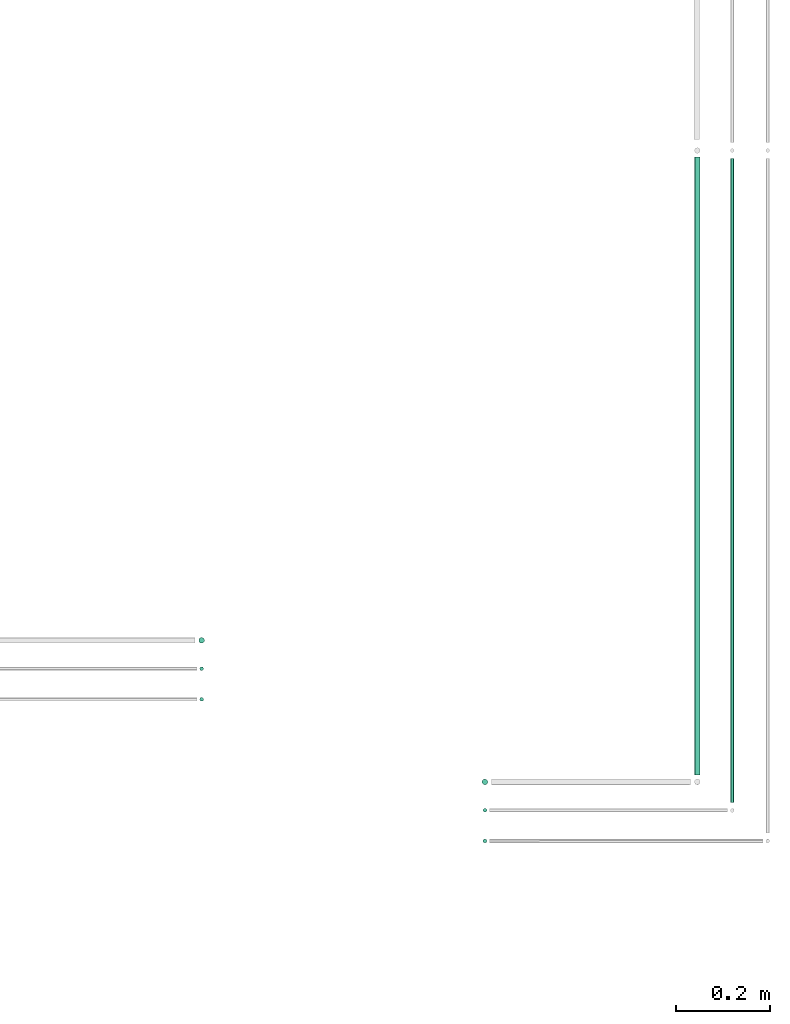
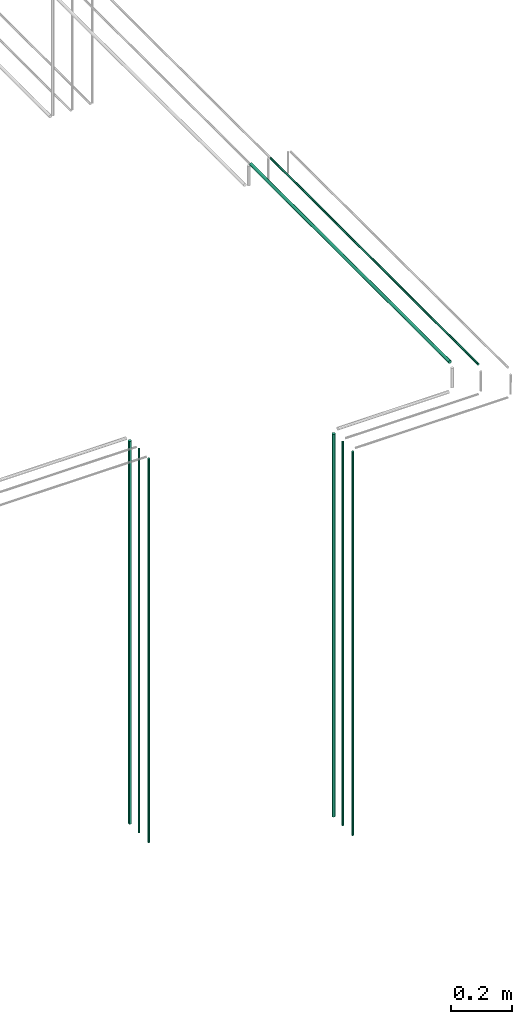
# One storey, part 70 of 331: 8 flow segments.
"""IFC2X3 building model written with IfcOpenShell, lengths in millimetres."""

from ifc_helpers import new_model, entity, si_unit, converted_unit, derived_unit, direction, frame, frame_2d, origin, origin_2d_with_axis, place, context, subcontext, project, spatial, circle, extrude, type_object, element, save


model = new_model("IFC2X3")

# Units and contexts
model_context = context("Model", 3, precision=0.01, world=origin(), true_north=direction((6.12303176911189e-17, 1.0)))
body_context = subcontext(model_context, "Body", "Model", "MODEL_VIEW")
ifc_project = project(units=[si_unit("LENGTHUNIT", "METRE", prefix="MILLI"), si_unit("AREAUNIT", "SQUARE_METRE"), si_unit("VOLUMEUNIT", "CUBIC_METRE"), converted_unit("PLANEANGLEUNIT", "DEGREE", entity("IfcRatioMeasure", 0.0174532925199433), si_unit("PLANEANGLEUNIT", "RADIAN"), dimensions=[0, 0, 0, 0, 0, 0, 0]), si_unit("MASSUNIT", "GRAM", prefix="KILO"), derived_unit("MASSDENSITYUNIT", [(si_unit("MASSUNIT", "GRAM", prefix="KILO"), 1), (si_unit("LENGTHUNIT", "METRE"), -3)]), derived_unit("MOMENTOFINERTIAUNIT", [(si_unit("LENGTHUNIT", "METRE"), 4)]), si_unit("TIMEUNIT", "SECOND"), si_unit("FREQUENCYUNIT", "HERTZ"), si_unit("THERMODYNAMICTEMPERATUREUNIT", "DEGREE_CELSIUS"), derived_unit("THERMALTRANSMITTANCEUNIT", [(si_unit("MASSUNIT", "GRAM", prefix="KILO"), 1), (si_unit("THERMODYNAMICTEMPERATUREUNIT", "KELVIN"), -1), (si_unit("TIMEUNIT", "SECOND"), -3)]), derived_unit("VOLUMETRICFLOWRATEUNIT", [(si_unit("LENGTHUNIT", "METRE"), 3), (si_unit("TIMEUNIT", "SECOND"), -1)]), derived_unit("MASSFLOWRATEUNIT", [(si_unit("MASSUNIT", "GRAM", prefix="KILO"), 1), (si_unit("TIMEUNIT", "SECOND"), -1)]), derived_unit("ROTATIONALFREQUENCYUNIT", [(si_unit("TIMEUNIT", "SECOND"), -1)]), si_unit("ELECTRICCURRENTUNIT", "AMPERE"), si_unit("ELECTRICVOLTAGEUNIT", "VOLT"), si_unit("POWERUNIT", "WATT"), si_unit("FORCEUNIT", "NEWTON", prefix="KILO"), si_unit("ILLUMINANCEUNIT", "LUX"), si_unit("LUMINOUSFLUXUNIT", "LUMEN"), si_unit("LUMINOUSINTENSITYUNIT", "CANDELA"), derived_unit("USERDEFINED", [(si_unit("MASSUNIT", "GRAM", prefix="KILO"), -1), (si_unit("LENGTHUNIT", "METRE"), -2), (si_unit("TIMEUNIT", "SECOND"), 3), (si_unit("LUMINOUSFLUXUNIT", "LUMEN"), 1)]), derived_unit("LINEARVELOCITYUNIT", [(si_unit("LENGTHUNIT", "METRE"), 1), (si_unit("TIMEUNIT", "SECOND"), -1)]), si_unit("PRESSUREUNIT", "PASCAL"), derived_unit("USERDEFINED", [(si_unit("LENGTHUNIT", "METRE"), -2), (si_unit("MASSUNIT", "GRAM", prefix="KILO"), 1), (si_unit("TIMEUNIT", "SECOND"), -2)]), derived_unit("LINEARFORCEUNIT", [(si_unit("MASSUNIT", "GRAM", prefix="KILO"), 1), (si_unit("LENGTHUNIT", "METRE"), 1), (si_unit("TIMEUNIT", "SECOND"), -2), (si_unit("LENGTHUNIT", "METRE"), -1)]), derived_unit("PLANARFORCEUNIT", [(si_unit("MASSUNIT", "GRAM", prefix="KILO"), 1), (si_unit("LENGTHUNIT", "METRE"), 1), (si_unit("TIMEUNIT", "SECOND"), -2), (si_unit("LENGTHUNIT", "METRE"), -2)])], contexts=[model_context])

# Site, building, storey
site_placement = place(None, frame((0.0, -0.00077364408347762, 0.0)))
site = spatial("IfcSite", under=ifc_project, at=site_placement, CompositionType="ELEMENT")
building_placement = place(site_placement, origin())
building = spatial("IfcBuilding", under=site, at=building_placement, CompositionType="ELEMENT")
storey_placement = place(building_placement, origin())
storey = spatial("IfcBuildingStorey", under=building, at=storey_placement, CompositionType="ELEMENT", Elevation=0.0)

# Flow segments
pipe_segment_type = type_object("IfcPipeSegmentType", PredefinedType="NOTDEFINED")
flow_segment_1_placement = place(building_placement, frame((66962.4038732719, 2867.4045477104, 5700.0)))
element("IfcFlowSegment", 1, at=flow_segment_1_placement, inside=storey, type_object=pipe_segment_type, context=body_context, shape_type="SweptSolid", body=[
    extrude(circle(Radius=6.0, at=frame_2d((0.0, 5.41433564649196e-13), x_axis=(1.0, 0.0))), frame((7.59527223591454, 7.59527223591562, 0.0)), (0.0, 0.0, 1.0), 1536.0),
])
for number, where in (
    (2, (66964.4038732719, 2809.40537015913, 5700.0)),
    (3, (66964.4038732719, 2744.40537015912, 5700.0)),
):
    element("IfcFlowSegment", number, at=place(building_placement, frame(where)), inside=storey, type_object=pipe_segment_type, context=body_context, shape_type="SweptSolid", body=[
        extrude(circle(Radius=4.0, at=origin_2d_with_axis()), frame((5.59527223591499, 5.59527223591607, 0.0)), (0.0, 0.0, 1.0), 1540.0),
    ])
flow_segment_2_placement = place(storey_placement, frame((67562.6293488116, 2567.4045477104, 5700.0)))
element("IfcFlowSegment", 4, at=flow_segment_2_placement, inside=storey, type_object=pipe_segment_type, context=body_context, shape_type="SweptSolid", body=[
    extrude(circle(Radius=6.0, at=origin_2d_with_axis()), frame((7.59527223591454, 7.59527223591616, 0.0)), (0.0, 0.0, 1.0), 1536.0),
])
for number, where in (
    (5, (67564.6293488116, 2509.40537015913, 5700.0)),
    (6, (67564.6293488116, 2444.40537015912, 5700.0)),
):
    element("IfcFlowSegment", number, at=place(storey_placement, frame(where)), inside=storey, type_object=pipe_segment_type, context=body_context, shape_type="SweptSolid", body=[
        extrude(circle(Radius=4.0, at=origin_2d_with_axis()), frame((5.59527223591499, 5.59527223591607, 0.0)), (0.0, 0.0, 1.0), 1540.0),
    ])
flow_segment_3_placement = place(storey_placement, frame((68012.5100168243, 2589.41432859278, 7348.40472776408)))
element("IfcFlowSegment", 7, at=flow_segment_3_placement, inside=storey, type_object=pipe_segment_type, context=body_context, shape_type="SweptSolid", body=[
    extrude(circle(Radius=6.0, at=frame_2d((0.0, -2.16573425859679e-12), x_axis=(1.0, 0.0))), frame((7.59527223591454, 0.0, 7.59527223591345), z_axis=(0.0, 1.0, 0.0), x_axis=(-1.0, 0.0, 0.0)), (0.0, 0.0, 1.0), 1309.08552411484),
])
flow_segment_4_placement = place(storey_placement, frame((68088.5232052591, 2532.00064239503, 7350.40472776407)))
element("IfcFlowSegment", 8, at=flow_segment_4_placement, inside=storey, type_object=pipe_segment_type, context=body_context, shape_type="SweptSolid", body=[
    extrude(circle(Radius=4.0, at=frame_2d((8.66293703438714e-12, 2.16573425859679e-12), x_axis=(1.0, 0.0))), frame((5.59527223592365, 0.0, 5.59527223591824), z_axis=(0.0, 1.0, 0.0), x_axis=(-1.0, 0.0, 0.0)), (0.0, 0.0, 1.0), 1363.49921031258),
])

save(model, "model.ifc")
